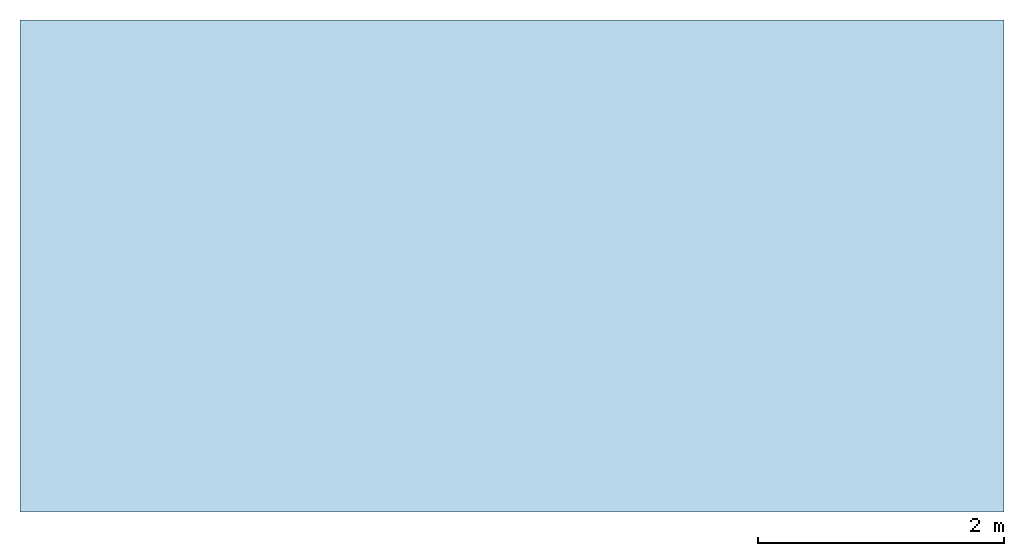
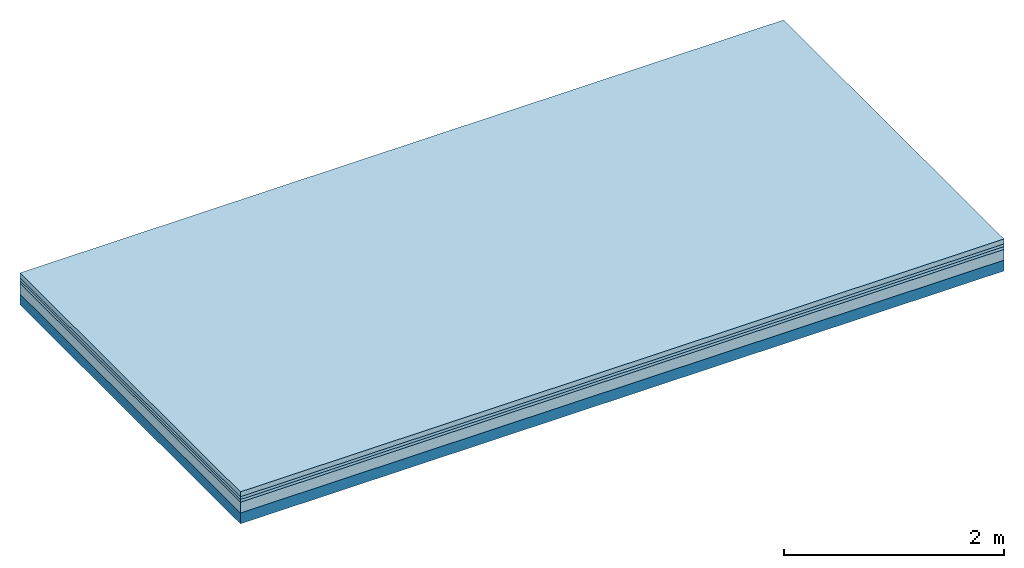
# One storey: 4 plates, 1 member, 1 element without a shape of its own.
"""IFC4 building model written with IfcOpenShell, lengths in metres."""

from ifc_helpers import new_model, si_unit, derived_unit, direction, frame, frame_2d, origin, origin_with_axes, place, context, project, spatial, rectangle, extrude, material, layer, layer_set, type_object, element, aggregate, save


model = new_model("IFC4")

# Units and contexts
plan_context = context("Plan", 3, precision=1e-05, world=origin(), true_north=direction((0.0, 1.0)))
model_context = context("Model", 3, precision=1e-05, world=origin(), true_north=direction((0.0, 1.0)))
ifc_project = project(units=[si_unit("LENGTHUNIT", "METRE"), derived_unit("SOUNDPRESSUREUNIT", [(si_unit("PRESSUREUNIT", "PASCAL", prefix="MICRO"), 0)]), si_unit("ENERGYUNIT", "JOULE", prefix="MEGA"), si_unit("MASSUNIT", "GRAM", prefix="KILO"), derived_unit("THERMALTRANSMITTANCEUNIT", [(si_unit("POWERUNIT", "WATT"), 1), (si_unit("AREAUNIT", "SQUARE_METRE"), -1), (si_unit("THERMODYNAMICTEMPERATUREUNIT", "KELVIN"), -1)]), derived_unit("AREADENSITYUNIT", [(si_unit("MASSUNIT", "GRAM", prefix="KILO"), 1), (si_unit("AREAUNIT", "SQUARE_METRE"), -1)]), derived_unit("USERDEFINED", [(si_unit("ENERGYUNIT", "JOULE", prefix="MEGA"), 1), (si_unit("AREAUNIT", "SQUARE_METRE"), -1)])], contexts=[plan_context, model_context])

# Site, building, storey
site = spatial("IfcSite", under=ifc_project)
building_placement = place(None, origin())
building = spatial("IfcBuilding", under=site, at=building_placement)
storey_placement = place(building_placement, origin())
storey = spatial("IfcBuildingStorey", under=building, at=storey_placement)

# Slab, member, plates
ifc_material_1 = material(Category="04.005")
ifc_layer_1 = layer(ifc_material_1, 0.055, Name="On-material")
ifc_material_2 = material()
ifc_layer_2 = layer(ifc_material_2, 0.03, Name="Impact sound insulation")
ifc_material_3 = material()
ifc_layer_3 = layer(ifc_material_3, 0.03, Name="Additional insulation")
ifc_material_4 = material(Category="01.042")
ifc_layer_4 = layer(ifc_material_4, 0.12, Name="on Supporting structure")
ifc_material_5 = material(Name="of the art")
ifc_layer_5 = layer(ifc_material_5, 0.0, Name="Bond")
ifc_layer_6 = layer(None, 0.12, Name="Supporting structure")
ifc_layer_set = layer_set([ifc_layer_1, ifc_layer_2, ifc_layer_3, ifc_layer_4, ifc_layer_5, ifc_layer_6])
slab_type = type_object("IfcSlabType", Name="A1349", PredefinedType="NOTDEFINED", material=ifc_layer_set)
slab_placement = place(None, frame((0.0, 0.0, 0.0), z_axis=(0.0, 0.0, -1.0), x_axis=(1.0, 0.0, 0.0)))
slab = element("IfcSlab", 1, at=slab_placement, inside=storey, type_object=slab_type, material=ifc_layer_set, Name="Slab #1")
ifc_material_6 = material()
member_placement = place(slab_placement, origin())
member = element("IfcMember", 2, at=member_placement, material=ifc_material_6, Name="Supporting structure", context=plan_context, shape_type="SweptSolid", body=[
    extrude(rectangle(XDim=1.0, YDim=0.12, at=frame_2d((0.5, 0.06), x_axis=(1.0, 0.0))), frame((0.0, 4.0, 0.235), z_axis=(0.0, -1.0, 0.0), x_axis=(1.0, 0.0, 0.0)), (0.0, 0.0, 1.0), 4.0),
    extrude(rectangle(XDim=1.0, YDim=0.12, at=frame_2d((0.5, 0.06), x_axis=(1.0, 0.0))), frame((1.0, 4.0, 0.235), z_axis=(0.0, -1.0, 0.0), x_axis=(1.0, 0.0, 0.0)), (0.0, 0.0, 1.0), 4.0),
    extrude(rectangle(XDim=1.0, YDim=0.12, at=frame_2d((0.5, 0.06), x_axis=(1.0, 0.0))), frame((2.0, 4.0, 0.235), z_axis=(0.0, -1.0, 0.0), x_axis=(1.0, 0.0, 0.0)), (0.0, 0.0, 1.0), 4.0),
    extrude(rectangle(XDim=1.0, YDim=0.12, at=frame_2d((0.5, 0.06), x_axis=(1.0, 0.0))), frame((3.0, 4.0, 0.235), z_axis=(0.0, -1.0, 0.0), x_axis=(1.0, 0.0, 0.0)), (0.0, 0.0, 1.0), 4.0),
    extrude(rectangle(XDim=1.0, YDim=0.12, at=frame_2d((0.5, 0.06), x_axis=(1.0, 0.0))), frame((4.0, 4.0, 0.235), z_axis=(0.0, -1.0, 0.0), x_axis=(1.0, 0.0, 0.0)), (0.0, 0.0, 1.0), 4.0),
    extrude(rectangle(XDim=1.0, YDim=0.12, at=frame_2d((0.5, 0.06), x_axis=(1.0, 0.0))), frame((5.0, 4.0, 0.235), z_axis=(0.0, -1.0, 0.0), x_axis=(1.0, 0.0, 0.0)), (0.0, 0.0, 1.0), 4.0),
    extrude(rectangle(XDim=1.0, YDim=0.12, at=frame_2d((0.5, 0.06), x_axis=(1.0, 0.0))), frame((6.0, 4.0, 0.235), z_axis=(0.0, -1.0, 0.0), x_axis=(1.0, 0.0, 0.0)), (0.0, 0.0, 1.0), 4.0),
    extrude(rectangle(XDim=1.0, YDim=0.12, at=frame_2d((0.5, 0.06), x_axis=(1.0, 0.0))), frame((7.0, 4.0, 0.235), z_axis=(0.0, -1.0, 0.0), x_axis=(1.0, 0.0, 0.0)), (0.0, 0.0, 1.0), 4.0),
])
plate_1_placement = place(slab_placement, origin())
plate_1 = element("IfcPlate", 3, at=plate_1_placement, material=ifc_material_1, Name="On-material", context=plan_context, shape_type="SweptSolid", body=[
    extrude(rectangle(XDim=8.0, YDim=4.0, at=frame_2d((4.0, 2.0), x_axis=(1.0, 0.0))), origin_with_axes(), (0.0, 0.0, 1.0), 0.055),
])
plate_2_placement = place(slab_placement, origin())
plate_2 = element("IfcPlate", 4, at=plate_2_placement, material=ifc_material_2, Name="Impact sound insulation", context=plan_context, shape_type="SweptSolid", body=[
    extrude(rectangle(XDim=8.0, YDim=4.0, at=frame_2d((4.0, 2.0), x_axis=(1.0, 0.0))), frame((0.0, 0.0, 0.055), z_axis=(0.0, 0.0, 1.0), x_axis=(1.0, 0.0, 0.0)), (0.0, 0.0, 1.0), 0.03),
])
plate_3_placement = place(slab_placement, origin())
plate_3 = element("IfcPlate", 5, at=plate_3_placement, material=ifc_material_3, Name="Additional insulation", context=plan_context, shape_type="SweptSolid", body=[
    extrude(rectangle(XDim=8.0, YDim=4.0, at=frame_2d((4.0, 2.0), x_axis=(1.0, 0.0))), frame((0.0, 0.0, 0.085), z_axis=(0.0, 0.0, 1.0), x_axis=(1.0, 0.0, 0.0)), (0.0, 0.0, 1.0), 0.03),
])
plate_4_placement = place(slab_placement, origin())
plate_4 = element("IfcPlate", 6, at=plate_4_placement, material=ifc_material_4, Name="on Supporting structure", context=plan_context, shape_type="SweptSolid", body=[
    extrude(rectangle(XDim=8.0, YDim=4.0, at=frame_2d((4.0, 2.0), x_axis=(1.0, 0.0))), frame((0.0, 0.0, 0.115), z_axis=(0.0, 0.0, 1.0), x_axis=(1.0, 0.0, 0.0)), (0.0, 0.0, 1.0), 0.12),
])
aggregate(slab, [plate_1, plate_2, plate_3, plate_4, member])

save(model, "model.ifc")
